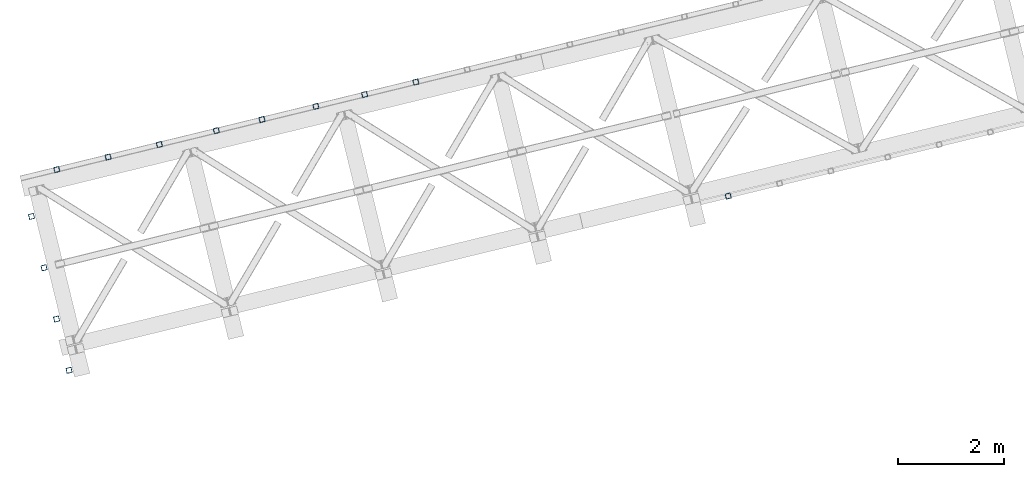
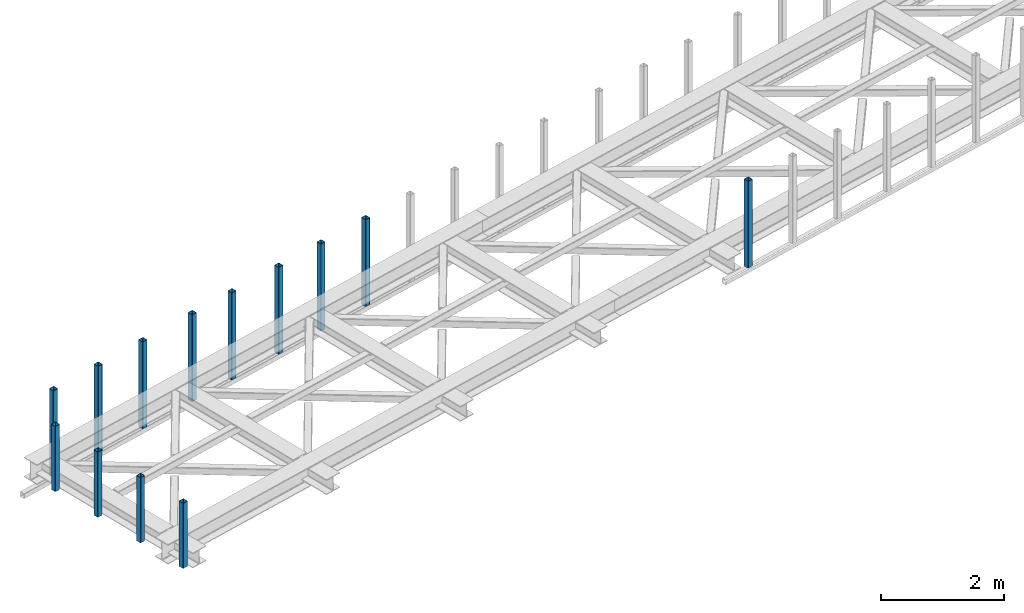
# One storey, part 1 of 66: 13 columns.
"""IFC4 building model written with IfcOpenShell, lengths in millimetres."""

from ifc_helpers import new_model, entity, si_unit, converted_unit, derived_unit, direction, frame, origin, place, context, subcontext, project, spatial, indexed_curve, outline, extrude, type_object, element, save


model = new_model("IFC4")

# Units and contexts
model_context = context("Model", 3, precision=0.01, world=origin(), true_north=direction((6.12303176911189e-17, 1.0)))
plan_context = context("Plan", 3, precision=0.01, world=origin(), true_north=direction((6.12303176911189e-17, 1.0)))
body_context = subcontext(model_context, "Body", "Model", "MODEL_VIEW")
ifc_project = project(units=[si_unit("LENGTHUNIT", "METRE", prefix="MILLI"), si_unit("AREAUNIT", "SQUARE_METRE"), si_unit("VOLUMEUNIT", "CUBIC_METRE"), converted_unit("PLANEANGLEUNIT", "DEGREE", entity("IfcRatioMeasure", 0.0174532925199433), si_unit("PLANEANGLEUNIT", "RADIAN"), dimensions=[0, 0, 0, 0, 0, 0, 0]), si_unit("MASSUNIT", "GRAM", prefix="KILO"), derived_unit("MASSDENSITYUNIT", [(si_unit("MASSUNIT", "GRAM", prefix="KILO"), 1), (si_unit("LENGTHUNIT", "METRE"), -3)]), derived_unit("MOMENTOFINERTIAUNIT", [(si_unit("LENGTHUNIT", "METRE"), 4)]), si_unit("TIMEUNIT", "SECOND"), si_unit("FREQUENCYUNIT", "HERTZ"), si_unit("THERMODYNAMICTEMPERATUREUNIT", "DEGREE_CELSIUS"), derived_unit("THERMALTRANSMITTANCEUNIT", [(si_unit("MASSUNIT", "GRAM", prefix="KILO"), 1), (si_unit("THERMODYNAMICTEMPERATUREUNIT", "KELVIN"), -1), (si_unit("TIMEUNIT", "SECOND"), -3)]), derived_unit("VOLUMETRICFLOWRATEUNIT", [(si_unit("LENGTHUNIT", "METRE"), 3), (si_unit("TIMEUNIT", "SECOND"), -1)]), derived_unit("MASSFLOWRATEUNIT", [(si_unit("MASSUNIT", "GRAM", prefix="KILO"), 1), (si_unit("TIMEUNIT", "SECOND"), -1)]), derived_unit("ROTATIONALFREQUENCYUNIT", [(si_unit("TIMEUNIT", "SECOND"), -1)]), si_unit("ELECTRICCURRENTUNIT", "AMPERE"), si_unit("ELECTRICVOLTAGEUNIT", "VOLT"), si_unit("POWERUNIT", "WATT"), si_unit("FORCEUNIT", "NEWTON", prefix="KILO"), si_unit("ILLUMINANCEUNIT", "LUX"), si_unit("LUMINOUSFLUXUNIT", "LUMEN"), si_unit("LUMINOUSINTENSITYUNIT", "CANDELA"), derived_unit("USERDEFINED", [(si_unit("MASSUNIT", "GRAM", prefix="KILO"), -1), (si_unit("LENGTHUNIT", "METRE"), -2), (si_unit("TIMEUNIT", "SECOND"), 3), (si_unit("LUMINOUSFLUXUNIT", "LUMEN"), 1)]), derived_unit("LINEARVELOCITYUNIT", [(si_unit("LENGTHUNIT", "METRE"), 1), (si_unit("TIMEUNIT", "SECOND"), -1)]), si_unit("PRESSUREUNIT", "PASCAL"), derived_unit("USERDEFINED", [(si_unit("LENGTHUNIT", "METRE"), -2), (si_unit("MASSUNIT", "GRAM", prefix="KILO"), 1), (si_unit("TIMEUNIT", "SECOND"), -2)]), derived_unit("LINEARFORCEUNIT", [(si_unit("MASSUNIT", "GRAM", prefix="KILO"), 1), (si_unit("LENGTHUNIT", "METRE"), 1), (si_unit("TIMEUNIT", "SECOND"), -2), (si_unit("LENGTHUNIT", "METRE"), -1)]), derived_unit("PLANARFORCEUNIT", [(si_unit("MASSUNIT", "GRAM", prefix="KILO"), 1), (si_unit("LENGTHUNIT", "METRE"), 1), (si_unit("TIMEUNIT", "SECOND"), -2), (si_unit("LENGTHUNIT", "METRE"), -2)])], contexts=[model_context, plan_context])

# Site, building, storey
site_placement = place(None, origin())
site = spatial("IfcSite", under=ifc_project, at=site_placement, CompositionType="ELEMENT")
building_placement = place(site_placement, origin())
building = spatial("IfcBuilding", under=site, at=building_placement, CompositionType="ELEMENT")
storey_placement = place(building_placement, frame((0.0, 0.0, 19800.0)))
storey = spatial("IfcBuildingStorey", under=building, at=storey_placement, Name="06", CompositionType="ELEMENT", Elevation=19800.0)

# Columns
column_type_1 = type_object("IfcColumnType", PredefinedType="COLUMN")
placement = place(storey_placement, origin())
element("IfcColumn", 1, at=placement, inside=storey, type_object=column_type_1, ObjectType="Steel Column", PredefinedType="COLUMN", context=body_context, shape_type="SweptSolid", body=[
    extrude(outline(indexed_curve([(29.4768951153626, -56.8428769007812), (33.3787015556899, -56.8428769007812), (36.9835006657251, -55.3497202197727), (39.7424944585471, -52.5907264269386), (41.235651139549, -48.985927316902), (56.842876900785, 29.4768951153656), (56.8428769007802, 33.3787015556904), (55.3497202197698, 36.983500665724), (52.5907264269414, 39.7424944585505), (48.9859273169057, 41.2356511395544), (-29.4768951153617, 56.8428769007831), (-33.3787015556895, 56.8428769007822), (-36.9835006657251, 55.3497202197727), (-39.7424944585466, 52.5907264269396), (-41.2356511395564, 48.9859273169066), (-56.8428769007845, -29.4768951153646), (-56.8428769007793, -33.3787015556884), (-55.3497202197694, -36.983500665723), (-52.5907264269404, -39.7424944585485), (-48.9859273169048, -41.2356511395524), (29.4768951153626, -56.8428769007812)], self_intersect=False), holes=[indexed_curve([(-43.1065493048113, -37.3071763476123), (-46.7113484148549, -35.8140196666048), (-49.4703422076833, -33.0550258737783), (-50.9634988886858, -29.4502267637483), (-50.9634988886832, -25.5484203234281), (-37.3071763476124, 43.1065493048114), (-35.8140196666113, 46.711348414846), (-33.0550258737806, 49.4703422076784), (-29.4502267637533, 50.9634988886906), (-25.5484203234334, 50.9634988886952), (43.1065493048044, 37.307176347618), (46.7113484148479, 35.8140196666104), (49.4703422076764, 33.0550258737839), (50.9634988886863, 29.4502267637493), (50.9634988886924, 25.5484203234274), (37.3071763476133, -43.1065493048094), (35.8140196666035, -46.7113484148423), (33.0550258737736, -49.4703422076728), (29.4502267637464, -50.9634988886849), (25.5484203234264, -50.9634988886896), (-43.1065493048113, -37.3071763476123)], self_intersect=False)]), frame((-53814.25, 7880.41, 3378.0), z_axis=(0.0, 0.0, 1.0), x_axis=(0.906681479027635, 0.421815949897891, 0.0)), (0.0, 0.0, 1.0), 1720.00000000001),
])
column_type_2 = type_object("IfcColumnType", PredefinedType="COLUMN")
element("IfcColumn", 2, at=placement, inside=storey, type_object=column_type_2, ObjectType="Steel Column", PredefinedType="COLUMN", context=body_context, shape_type="SweptSolid", body=[
    extrude(outline(indexed_curve([(29.4768951153024, -56.8428769008208), (33.3787015556224, -56.8428769008208), (36.9835006656593, -55.3497202198166), (39.7424944584924, -52.5907264269894), (41.2356511394987, -48.9859273169546), (56.8428769008278, 29.4768951152944), (56.8428769008277, 33.3787015556192), (55.3497202198212, 36.9835006656536), (52.5907264269881, 39.7424944584871), (48.9859273169621, 41.2356511394916), (-29.4768951152941, 56.8428769008181), (-33.3787015556141, 56.8428769008181), (-36.9835006656514, 55.349720219813), (-39.7424944584841, 52.5907264269867), (-41.2356511394908, 48.9859273169509), (-56.8428769008121, -29.4768951153017), (-56.8428769008115, -33.3787015556255), (-55.3497202198133, -36.9835006656573), (-52.5907264269798, -39.7424944584897), (-48.9859273169459, -41.2356511394979), (29.4768951153024, -56.8428769008208)], self_intersect=False), holes=[indexed_curve([(-43.1065493048478, -37.3071763475648), (-46.71134841489, -35.814019666554), (-49.4703422077148, -33.0550258737232), (-50.9634988887134, -29.4502267636924), (-50.9634988887057, -25.5484203233713), (-37.3071763475538, 43.106549304851), (-35.8140196665475, 46.7113484148858), (-33.0550258737149, 49.4703422077121), (-29.4502267636928, 50.9634988887255), (-25.5484203233654, 50.9634988887209), (43.106549304864, 37.3071763475585), (46.7113484148983, 35.8140196665513), (49.4703422077231, 33.0550258737205), (50.9634988887296, 29.4502267636861), (50.9634988887302, 25.5484203233623), (37.3071763475699, -43.1065493048573), (35.8140196665554, -46.7113484148895), (33.0550258737227, -49.4703422077157), (29.4502267637015, -50.9634988887272), (25.5484203233737, -50.9634988887236), (-43.1065493048478, -37.3071763475648)], self_intersect=False)]), frame((-54785.8, 7643.59, 3378.0), z_axis=(0.0, 0.0, 1.0), x_axis=(0.906681479027134, 0.421815949898968, 0.0)), (0.0, 0.0, 1.0), 1720.00000000001),
])
column_type_3 = type_object("IfcColumnType", PredefinedType="COLUMN")
element("IfcColumn", 3, at=placement, inside=storey, type_object=column_type_3, ObjectType="Steel Column", PredefinedType="COLUMN", context=body_context, shape_type="SweptSolid", body=[
    extrude(outline(indexed_curve([(29.4768951153557, -56.8428769007932), (33.3787015556835, -56.8428769007932), (36.9835006657111, -55.349720219782), (39.7424944585417, -52.5907264269522), (41.2356511395445, -48.985927316916), (56.8428769007924, 29.4768951153513), (56.842876900796, 33.3787015556714), (55.3497202197865, 36.9835006657054), (52.5907264269588, 39.7424944585326), (48.9859273169234, 41.2356511395375), (-29.4768951153474, 56.8428769007906), (-33.3787015556673, 56.8428769007869), (-36.9835006657033, 55.3497202197784), (-39.7424944585334, 52.5907264269495), (-41.2356511395367, 48.9859273169123), (-56.8428769007845, -29.4768951153549), (-56.8428769007881, -33.3787015556751), (-55.3497202197787, -36.9835006657091), (-52.5907264269426, -39.742494458539), (-48.9859273169073, -41.2356511395438), (29.4768951153557, -56.8428769007932)], self_intersect=False), holes=[indexed_curve([(-43.1065493048133, -37.3071763476062), (-46.7113484148565, -35.8140196665977), (-49.4703422076926, -33.0550258737678), (-50.9634988886858, -29.4502267637401), (-50.9634988886896, -25.5484203234153), (-37.3071763475941, 43.1065493048161), (-35.8140196665991, 46.711348414856), (-33.0550258737612, 49.4703422076811), (-29.4502267637405, 50.963498888698), (-25.5484203234131, 50.963498888697), (43.1065493048212, 37.3071763476025), (46.7113484148565, 35.8140196665977), (49.4703422076921, 33.0550258737668), (50.9634988887011, 29.4502267637318), (50.9634988886984, 25.5484203234136), (37.3071763476098, -43.1065493048234), (35.8140196665987, -46.711348414857), (33.0550258737612, -49.4703422076811), (29.4502267637409, -50.963498888697), (25.548420323421, -50.9634988887006), (-43.1065493048133, -37.3071763476062)], self_intersect=False)]), frame((-55708.78, 7418.6, 3378.0), z_axis=(0.0, 0.0, 1.0), x_axis=(0.906681479027529, 0.421815949898119, 0.0)), (0.0, 0.0, 1.0), 1720.00000000001),
])
column_type_4 = type_object("IfcColumnType", PredefinedType="COLUMN")
element("IfcColumn", 4, at=placement, inside=storey, type_object=column_type_4, ObjectType="Steel Column", PredefinedType="COLUMN", context=body_context, shape_type="SweptSolid", body=[
    extrude(outline(indexed_curve([(29.4768951153621, -56.8428769007822), (33.3787015556895, -56.8428769007822), (36.9835006657246, -55.3497202197737), (39.7424944585466, -52.5907264269396), (41.2356511395569, -48.9859273169056), (56.842876900785, 29.4768951153656), (56.8428769007797, 33.3787015556894), (55.3497202197694, 36.983500665723), (52.5907264269409, 39.7424944585495), (48.9859273169052, 41.2356511395534), (-29.47689511537, 56.8428769007858), (-33.3787015556895, 56.8428769007822), (-36.9835006657251, 55.3497202197727), (-39.7424944585471, 52.5907264269386), (-41.2356511395569, 48.9859273169056), (-56.842876900785, -29.4768951153656), (-56.8428769007797, -33.3787015556894), (-55.3497202197698, -36.983500665724), (-52.5907264269409, -39.7424944585495), (-48.9859273169052, -41.2356511395534), (29.4768951153621, -56.8428769007822)], self_intersect=False), holes=[indexed_curve([(-43.1065493048118, -37.3071763476133), (-46.7113484148558, -35.8140196666067), (-49.4703422076842, -33.0550258737802), (-50.9634988886858, -29.4502267637483), (-50.9634988886841, -25.5484203234301), (-37.3071763476128, 43.1065493048104), (-35.8140196666109, 46.711348414847), (-33.0550258737815, 49.4703422076765), (-29.4502267637616, 50.9634988886932), (-25.5484203234343, 50.9634988886932), (43.1065493048035, 37.307176347616), (46.711348414847, 35.8140196666084), (49.4703422076755, 33.0550258737819), (50.9634988886858, 29.4502267637483), (50.9634988886841, 25.5484203234301), (37.3071763476128, -43.1065493048104), (35.8140196666026, -46.7113484148443), (33.0550258737727, -49.4703422076748), (29.4502267637533, -50.9634988886906), (25.548420323426, -50.9634988886905), (-43.1065493048118, -37.3071763476133)], self_intersect=False)]), frame((-56728.91, 7169.93, 3378.0), z_axis=(0.0, 0.0, 1.0), x_axis=(0.906681479027635, 0.421815949897891, 0.0)), (0.0, 0.0, 1.0), 1720.00000000001),
])
column_type_5 = type_object("IfcColumnType", PredefinedType="COLUMN")
element("IfcColumn", 5, at=placement, inside=storey, type_object=column_type_5, ObjectType="Steel Column", PredefinedType="COLUMN", context=body_context, shape_type="SweptSolid", body=[
    extrude(outline(indexed_curve([(29.4768951153783, -56.8428769007885), (33.3787015557056, -56.8428769007885), (36.9835006657408, -55.34972021978), (39.7424944585628, -52.5907264269459), (41.235651139573, -48.985927316912), (56.8428769008011, 29.4768951153592), (56.8428769007959, 33.378701555683), (55.3497202197855, 36.9835006657167), (52.5907264269571, 39.7424944585432), (48.9859273169214, 41.2356511395471), (-29.4768951153538, 56.8428769007795), (-33.3787015556738, 56.8428769007749), (-36.9835006657089, 55.3497202197664), (-39.7424944585309, 52.5907264269322), (-41.2356511395407, 48.9859273168993), (-56.8428769007688, -29.4768951153719), (-56.8428769007636, -33.3787015556957), (-55.3497202197537, -36.9835006657303), (-52.5907264269247, -39.7424944585558), (-48.9859273168891, -41.2356511395598), (29.4768951153783, -56.8428769007885)], self_intersect=False), holes=[indexed_curve([(-43.1065493047956, -37.3071763476197), (-46.7113484148392, -35.8140196666121), (-49.4703422076676, -33.0550258737856), (-50.9634988886701, -29.4502267637556), (-50.9634988886675, -25.5484203234355), (-37.3071763475967, 43.106549304804), (-35.8140196665947, 46.7113484148406), (-33.0550258737653, 49.4703422076702), (-29.4502267637371, 50.9634988886842), (-25.5484203234181, 50.9634988886869), (43.1065493048201, 37.3071763476107), (46.7113484148636, 35.8140196666031), (49.4703422076921, 33.0550258737766), (50.9634988887025, 29.450226763743), (50.9634988887081, 25.5484203234201), (37.307176347629, -43.1065493048167), (35.8140196666192, -46.7113484148496), (33.0550258737893, -49.4703422076801), (29.4502267637699, -50.9634988886959), (25.5484203234421, -50.9634988886969), (-43.1065493047956, -37.3071763476197)], self_intersect=False)]), frame((-57593.59, 6959.16, 3378.0), z_axis=(0.0, 0.0, 1.0), x_axis=(0.906681479027635, 0.421815949897891, 0.0)), (0.0, 0.0, 1.0), 1720.00000000001),
])
column_type_6 = type_object("IfcColumnType", PredefinedType="COLUMN")
element("IfcColumn", 6, at=placement, inside=storey, type_object=column_type_6, ObjectType="Steel Column", PredefinedType="COLUMN", context=body_context, shape_type="SweptSolid", body=[
    extrude(outline(indexed_curve([(29.4768951153538, -56.8428769007795), (33.3787015556812, -56.8428769007795), (36.9835006657163, -55.349720219771), (39.7424944585383, -52.5907264269369), (41.2356511395485, -48.985927316903), (56.8428769007766, 29.4768951153682), (56.8428769007714, 33.378701555692), (55.3497202197611, 36.9835006657257), (52.5907264269326, 39.7424944585522), (48.9859273168969, 41.2356511395561), (-29.4768951153783, 56.8428769007885), (-33.3787015556983, 56.8428769007839), (-36.9835006657334, 55.3497202197754), (-39.7424944585554, 52.5907264269412), (-41.2356511395652, 48.9859273169083), (-56.8428769007933, -29.4768951153629), (-56.842876900788, -33.3787015556867), (-55.3497202197781, -36.9835006657213), (-52.5907264269492, -39.7424944585468), (-48.9859273169135, -41.2356511395508), (29.4768951153538, -56.8428769007795)], self_intersect=False), holes=[indexed_curve([(-43.1065493048205, -37.3071763476116), (-46.7113484148641, -35.8140196666041), (-49.4703422076926, -33.0550258737776), (-50.9634988886946, -29.4502267637466), (-50.9634988886924, -25.5484203234274), (-37.3071763476216, 43.106549304812), (-35.8140196666197, 46.7113484148486), (-33.0550258737898, 49.4703422076792), (-29.4502267637625, 50.9634988886913), (-25.5484203234426, 50.9634988886959), (43.1065493047952, 37.3071763476187), (46.7113484148387, 35.8140196666111), (49.4703422076672, 33.0550258737846), (50.9634988886775, 29.450226763751), (50.9634988886832, 25.5484203234281), (37.3071763476045, -43.1065493048077), (35.8140196665947, -46.7113484148406), (33.0550258737644, -49.4703422076721), (29.450226763745, -50.9634988886879), (25.5484203234172, -50.9634988886889), (-43.1065493048205, -37.3071763476116)], self_intersect=False)]), frame((-58672.01, 6696.28, 3378.0), z_axis=(0.0, 0.0, 1.0), x_axis=(0.906681479027635, 0.421815949897891, 0.0)), (0.0, 0.0, 1.0), 1720.00000000001),
])
column_type_7 = type_object("IfcColumnType", PredefinedType="COLUMN")
element("IfcColumn", 7, at=placement, inside=storey, type_object=column_type_7, ObjectType="Steel Column", PredefinedType="COLUMN", context=body_context, shape_type="SweptSolid", body=[
    extrude(outline(indexed_curve([(29.4768951153774, -56.8428769007905), (33.3787015557047, -56.8428769007905), (36.9835006657398, -55.349720219782), (39.7424944585618, -52.5907264269478), (41.2356511395721, -48.9859273169139), (56.8428769008002, 29.4768951153573), (56.842876900795, 33.3787015556811), (55.3497202197846, 36.9835006657147), (52.5907264269561, 39.7424944585412), (48.9859273169205, 41.2356511395451), (-29.4768951153547, 56.8428769007775), (-33.3787015556747, 56.8428769007729), (-36.9835006657098, 55.3497202197644), (-39.7424944585318, 52.5907264269303), (-41.2356511395416, 48.9859273168973), (-56.8428769007697, -29.4768951153739), (-56.8428769007645, -33.3787015556977), (-55.3497202197546, -36.9835006657323), (-52.5907264269256, -39.7424944585578), (-48.98592731689, -41.2356511395617), (29.4768951153774, -56.8428769007905)], self_intersect=False), holes=[indexed_curve([(-43.1065493047965, -37.3071763476216), (-46.7113484148401, -35.8140196666141), (-49.4703422076685, -33.0550258737875), (-50.963498888671, -29.4502267637576), (-50.9634988886684, -25.5484203234374), (-37.307176347598, 43.1065493048011), (-35.8140196665961, 46.7113484148377), (-33.0550258737662, 49.4703422076682), (-29.4502267637385, 50.9634988886813), (-25.5484203234186, 50.9634988886859), (43.106549304827, 37.307176347605), (46.7113484148627, 35.8140196666011), (49.4703422076912, 33.0550258737746), (50.9634988887015, 29.450226763741), (50.9634988887068, 25.5484203234172), (37.3071763476281, -43.1065493048187), (35.8140196666183, -46.7113484148516), (33.055025873788, -49.4703422076831), (29.450226763769, -50.9634988886979), (25.5484203234412, -50.9634988886988), (-43.1065493047965, -37.3071763476216)], self_intersect=False)]), frame((-59643.56, 6459.45, 3378.0), z_axis=(0.0, 0.0, 1.0), x_axis=(0.906681479027635, 0.421815949897891, 0.0)), (0.0, 0.0, 1.0), 1720.00000000001),
])
column_type_8 = type_object("IfcColumnType", PredefinedType="COLUMN")
element("IfcColumn", 8, at=placement, inside=storey, type_object=column_type_8, ObjectType="Steel Column", PredefinedType="COLUMN", context=body_context, shape_type="SweptSolid", body=[
    extrude(outline(indexed_curve([(29.4768951153621, -56.8428769007822), (33.3787015556895, -56.8428769007822), (36.9835006657246, -55.3497202197737), (39.7424944585466, -52.5907264269396), (41.2356511395569, -48.9859273169056), (56.842876900785, 29.4768951153656), (56.8428769007797, 33.3787015556894), (55.3497202197694, 36.983500665723), (52.5907264269409, 39.7424944585495), (48.9859273169052, 41.2356511395534), (-29.47689511537, 56.8428769007858), (-33.3787015556895, 56.8428769007822), (-36.9835006657251, 55.3497202197727), (-39.7424944585471, 52.5907264269386), (-41.2356511395569, 48.9859273169056), (-56.842876900785, -29.4768951153656), (-56.8428769007797, -33.3787015556894), (-55.3497202197698, -36.983500665724), (-52.5907264269409, -39.7424944585495), (-48.9859273169052, -41.2356511395534), (29.4768951153621, -56.8428769007822)], self_intersect=False), holes=[indexed_curve([(-43.1065493048113, -37.3071763476123), (-46.7113484148553, -35.8140196666058), (-49.4703422076838, -33.0550258737792), (-50.9634988886858, -29.4502267637483), (-50.9634988886837, -25.5484203234291), (-37.3071763476128, 43.1065493048104), (-35.8140196666109, 46.711348414847), (-33.055025873781, 49.4703422076775), (-29.4502267637533, 50.9634988886906), (-25.5484203234338, 50.9634988886942), (43.1065493048044, 37.307176347618), (46.7113484148475, 35.8140196666094), (49.4703422076764, 33.0550258737839), (50.9634988886867, 29.4502267637503), (50.963498888692, 25.5484203234265), (37.3071763476133, -43.1065493048094), (35.8140196666035, -46.7113484148423), (33.0550258737736, -49.4703422076728), (29.4502267637542, -50.9634988886886), (25.5484203234264, -50.9634988886896), (-43.1065493048113, -37.3071763476123)], self_intersect=False)]), frame((-60615.11, 6222.63, 3378.0), z_axis=(0.0, 0.0, 1.0), x_axis=(0.906681479027635, 0.421815949897891, 0.0)), (0.0, 0.0, 1.0), 1720.00000000001),
])
column_type_9 = type_object("IfcColumnType", PredefinedType="COLUMN")
element("IfcColumn", 9, at=placement, inside=storey, type_object=column_type_9, ObjectType="Steel Column", PredefinedType="COLUMN", context=body_context, shape_type="SweptSolid", body=[
    extrude(outline(indexed_curve([(29.4768951153325, -56.8428769008207), (33.3787015556519, -56.8428769008207), (36.9835006656889, -55.3497202198146), (39.7424944585135, -52.5907264269831), (41.2356511395267, -48.9859273169515), (56.8428769008283, 29.4768951153051), (56.8428769008267, 33.3787015556289), (55.3497202198197, 36.9835006656639), (52.5907264269934, 39.742494458492), (48.9859273169595, 41.2356511395003), (-29.4768951152932, 56.8428769008024), (-33.378701555621, 56.8428769008051), (-36.9835006656575, 55.3497202198), (-39.7424944584816, 52.5907264269694), (-41.2356511394953, 48.9859273169369), (-56.8428769007968, -29.4768951153197), (-56.8428769007953, -33.3787015556435), (-55.3497202197883, -36.9835006656785), (-52.5907264269624, -39.7424944585076), (-48.9859273169281, -41.2356511395149), (29.4768951153325, -56.8428769008207)], self_intersect=False), holes=[indexed_curve([(-43.1065493048305, -37.3071763475793), (-46.7113484148653, -35.814019666573), (-49.4703422076916, -33.0550258737449), (-50.9634988886982, -29.4502267637089), (-50.9634988886993, -25.5484203233841), (-37.3071763475568, 43.106549304838), (-35.8140196665514, 46.7113484148732), (-33.055025873719, 49.4703422077011), (-29.4502267636903, 50.9634988887098), (-25.5484203233625, 50.9634988887071), (43.1065493048546, 37.3071763475693), (46.7113484148967, 35.8140196665584), (49.4703422077231, 33.0550258737303), (50.9634988887296, 29.4502267636943), (50.9634988887238, 25.5484203233751), (37.3071763475886, -43.1065493048516), (35.8140196665828, -46.7113484148878), (33.0550258737509, -49.4703422077147), (29.4502267637139, -50.9634988887208), (25.5484203233944, -50.9634988887208), (-43.1065493048305, -37.3071763475793)], self_intersect=False)]), frame((-61093.29, 5334.11, 3808.0), z_axis=(0.0, 0.0, 1.0), x_axis=(0.90668147902724, 0.42181594989874, 0.0)), (0.0, 0.0, 1.0), 1290.00000000001),
])
column_type_10 = type_object("IfcColumnType", PredefinedType="COLUMN")
element("IfcColumn", 10, at=placement, inside=storey, type_object=column_type_10, ObjectType="Steel Column", PredefinedType="COLUMN", context=body_context, shape_type="SweptSolid", body=[
    extrude(outline(indexed_curve([(29.4768951153013, -56.8428769008144), (33.378701555621, -56.8428769008144), (36.9835006656579, -55.3497202198093), (39.7424944584829, -52.5907264269781), (41.2356511394967, -48.9859273169462), (56.8428769008082, 29.4768951153084), (56.8428769008071, 33.3787015556322), (55.3497202198006, 36.9835006656674), (52.5907264269748, 39.7424944584964), (48.9859273169405, 41.2356511395036), (-29.4768951153179, 56.8428769008198), (-33.3787015556374, 56.8428769008203), (-36.9835006656743, 55.3497202198151), (-39.742494458499, 52.5907264269844), (-41.2356511395129, 48.9859273169526), (-56.8428769008244, -29.4768951153021), (-56.8428769008233, -33.3787015556259), (-55.349720219817, -36.9835006656616), (-52.5907264269912, -39.7424944584905), (-48.9859273169571, -41.2356511394983), (29.4768951153013, -56.8428769008144)], self_intersect=False), holes=[indexed_curve([(-43.1065493048595, -37.3071763475644), (-46.7113484149015, -35.814019666553), (-49.4703422077272, -33.0550258737241), (-50.9634988887257, -29.450226763692), (-50.963498888727, -25.5484203233687), (-37.3071763475754, 43.1065493048526), (-35.8140196665696, 46.7113484148876), (-33.0550258737366, 49.4703422077157), (-29.4502267637158, 50.9634988887272), (-25.548420323388, 50.963498888724), (43.1065493048274, 37.3071763475776), (46.711348414877, 35.814019666562), (49.4703422077027, 33.0550258737331), (50.9634988887093, 29.4502267636979), (50.9634988887027, 25.5484203233782), (37.3071763475587, -43.1065493048473), (35.8140196665453, -46.7113484148782), (33.0550258737125, -49.4703422077057), (29.4502267636835, -50.9634988887145), (25.5484203233637, -50.9634988887145), (-43.1065493048595, -37.3071763475644)], self_intersect=False)]), frame((-60856.47, 4362.56, 3808.0), z_axis=(0.0, 0.0, 1.0), x_axis=(0.906681479027187, 0.421815949898854, 0.0)), (0.0, 0.0, 1.0), 1290.00000000001),
])
column_type_11 = type_object("IfcColumnType", PredefinedType="COLUMN")
element("IfcColumn", 11, at=placement, inside=storey, type_object=column_type_11, ObjectType="Steel Column", PredefinedType="COLUMN", context=body_context, shape_type="SweptSolid", body=[
    extrude(outline(indexed_curve([(29.4768951153094, -56.8428769008176), (33.3787015556291, -56.8428769008176), (36.983500665666, -55.3497202198125), (39.742494458491, -52.5907264269812), (41.2356511395048, -48.9859273169494), (56.8428769008163, 29.4768951153052), (56.8428769008152, 33.378701555629), (55.3497202198087, 36.9835006656642), (52.5907264269829, 39.7424944584932), (48.9859273169488, 41.2356511395009), (-29.4768951153017, 56.8428769008134), (-33.3787015556293, 56.8428769008171), (-36.9835006656662, 55.349720219812), (-39.7424944584912, 52.5907264269807), (-41.2356511395048, 48.9859273169494), (-56.8428769008163, -29.4768951153052), (-56.8428769008152, -33.378701555629), (-55.3497202198089, -36.9835006656647), (-52.5907264269831, -39.7424944584937), (-48.985927316949, -41.2356511395014), (29.4768951153094, -56.8428769008176)], self_intersect=False), holes=[indexed_curve([(-43.1065493048514, -37.3071763475676), (-46.7113484148853, -35.8140196665594), (-49.4703422077113, -33.0550258737309), (-50.9634988887176, -29.4502267636952), (-50.9634988887187, -25.5484203233714), (-37.307176347567, 43.10654930485), (-35.8140196665613, 46.711348414885), (-33.0550258737285, 49.4703422077125), (-29.4502267636994, 50.9634988887213), (-25.548420323372, 50.9634988887172), (43.1065493048433, 37.3071763475707), (46.7113484148853, 35.8140196665594), (49.470342207711, 33.0550258737304), (50.9634988887176, 29.4502267636952), (50.9634988887108, 25.548420323375), (37.307176347567, -43.10654930485), (35.8140196665613, -46.711348414885), (33.0550258737285, -49.4703422077125), (29.4502267636918, -50.9634988887172), (25.5484203233718, -50.9634988887177), (-43.1065493048514, -37.3071763475676)], self_intersect=False)]), frame((-60619.64, 3391.0, 3808.0), z_axis=(0.0, 0.0, 1.0), x_axis=(0.906681479027187, 0.421815949898854, 0.0)), (0.0, 0.0, 1.0), 1290.00000000001),
])
column_type_12 = type_object("IfcColumnType", PredefinedType="COLUMN")
element("IfcColumn", 12, at=placement, inside=storey, type_object=column_type_12, ObjectType="Steel Column", PredefinedType="COLUMN", context=body_context, shape_type="SweptSolid", body=[
    extrude(outline(indexed_curve([(29.476895115314, -56.8428769008224), (33.3787015556338, -56.8428769008224), (36.9835006656707, -55.3497202198177), (39.7424944584958, -52.5907264269867), (41.2356511395098, -48.9859273169552), (56.8428769008263, 29.4768951152987), (56.8428769008255, 33.3787015556225), (55.3497202198192, 36.9835006656578), (52.5907264269936, 39.742494458487), (48.9859273169596, 41.2356511394949), (-29.4768951152902, 56.8428769008119), (-33.3787015556175, 56.8428769008163), (-36.9835006656546, 55.3497202198114), (-39.7424944584797, 52.5907264269803), (-41.2356511394935, 48.9859273169491), (-56.84287690081, -29.4768951153048), (-56.8428769008092, -33.3787015556286), (-55.349720219803, -36.9835006656642), (-52.5907264269774, -39.7424944584933), (-48.9859273169434, -41.2356511395013), (29.476895115314, -56.8428769008224)], self_intersect=False), holes=[indexed_curve([(-43.1065493048456, -37.3071763475678), (-46.7113484148796, -35.8140196665598), (-49.4703422077052, -33.0550258737307), (-50.9634988887113, -29.4502267636951), (-50.9634988887123, -25.5484203233716), (-37.3071763475564, 43.1065493048489), (-35.8140196665504, 46.7113484148838), (-33.0550258737174, 49.4703422077112), (-29.4502267636882, 50.9634988887198), (-25.5484203233606, 50.9634988887159), (43.1065493048539, 37.3071763475651), (46.7113484148957, 35.8140196665535), (49.4703422077211, 33.0550258737239), (50.9634988887274, 29.4502267636886), (50.9634988887206, 25.5484203233689), (37.3071763475724, -43.1065493048555), (35.8140196665664, -46.7113484148904), (33.0550258737336, -49.4703422077175), (29.4502267636964, -50.9634988887227), (25.5484203233768, -50.9634988887222), (-43.1065493048456, -37.3071763475678)], self_intersect=False)]), frame((-60382.81, 2419.45, 3808.0), z_axis=(0.0, 0.0, 1.0), x_axis=(0.90668147902716, 0.421815949898911, 0.0)), (0.0, 0.0, 1.0), 1290.00000000001),
])
column_type_13 = type_object("IfcColumnType", PredefinedType="COLUMN")
element("IfcColumn", 13, at=placement, inside=storey, type_object=column_type_13, ObjectType="Steel Column", PredefinedType="COLUMN", context=body_context, shape_type="SweptSolid", body=[
    extrude(outline(indexed_curve([(29.4768951153272, -56.8428769007868), (33.3787015556517, -56.8428769007868), (36.9835006656889, -55.3497202197785), (39.7424944585122, -52.5907264269475), (41.2356511395214, -48.985927316913), (56.8428769008053, 29.4768951153436), (56.8428769008064, 33.3787015556652), (55.3497202197981, 36.9835006657), (52.5907264269709, 39.7424944585263), (48.9859273169297, 41.2356511395339), (-29.4768951153267, 56.8428769007878), (-33.3787015556517, 56.8428769007868), (-36.9835006656884, 55.3497202197795), (-39.7424944585122, 52.5907264269475), (-41.2356511395214, 48.985927316913), (-56.8428769008053, -29.4768951153436), (-56.8428769008059, -33.3787015556642), (-55.3497202197977, -36.983500665699), (-52.5907264269709, -39.7424944585263), (-48.9859273169297, -41.2356511395339), (29.4768951153272, -56.8428769007868)], self_intersect=False), holes=[indexed_curve([(-43.1065493048404, -37.3071763475933), (-46.7113484148742, -35.8140196665904), (-49.4703422077084, -33.0550258737584), (-50.9634988887093, -29.4502267637283), (-50.9634988887161, -25.548420323403), (-37.3071763475836, 43.1065493048179), (-35.8140196665748, 46.7113484148513), (-33.055025873751, 49.4703422076834), (-29.4502267637222, 50.9634988886944), (-25.5484203233889, 50.9634988886927), (43.10654930484, 37.3071763475923), (46.7113484148738, 35.8140196665894), (49.470342207701, 33.0550258737631), (50.963498888701, 29.450226763731), (50.9634988887082, 25.5484203234067), (37.3071763475762, -43.1065493048132), (35.8140196665753, -46.7113484148503), (33.0550258737589, -49.4703422076871), (29.4502267637143, -50.9634988886907), (25.5484203233889, -50.9634988886927), (-43.1065493048404, -37.3071763475933)], self_intersect=False)]), frame((-47899.04, 5719.66, 3378.01), z_axis=(0.0, 0.0, 1.0), x_axis=(-0.904974271849307, -0.425466293953842, 0.0)), (0.0, 0.0, 1.0), 1719.99999999989),
])

save(model, "model.ifc")
